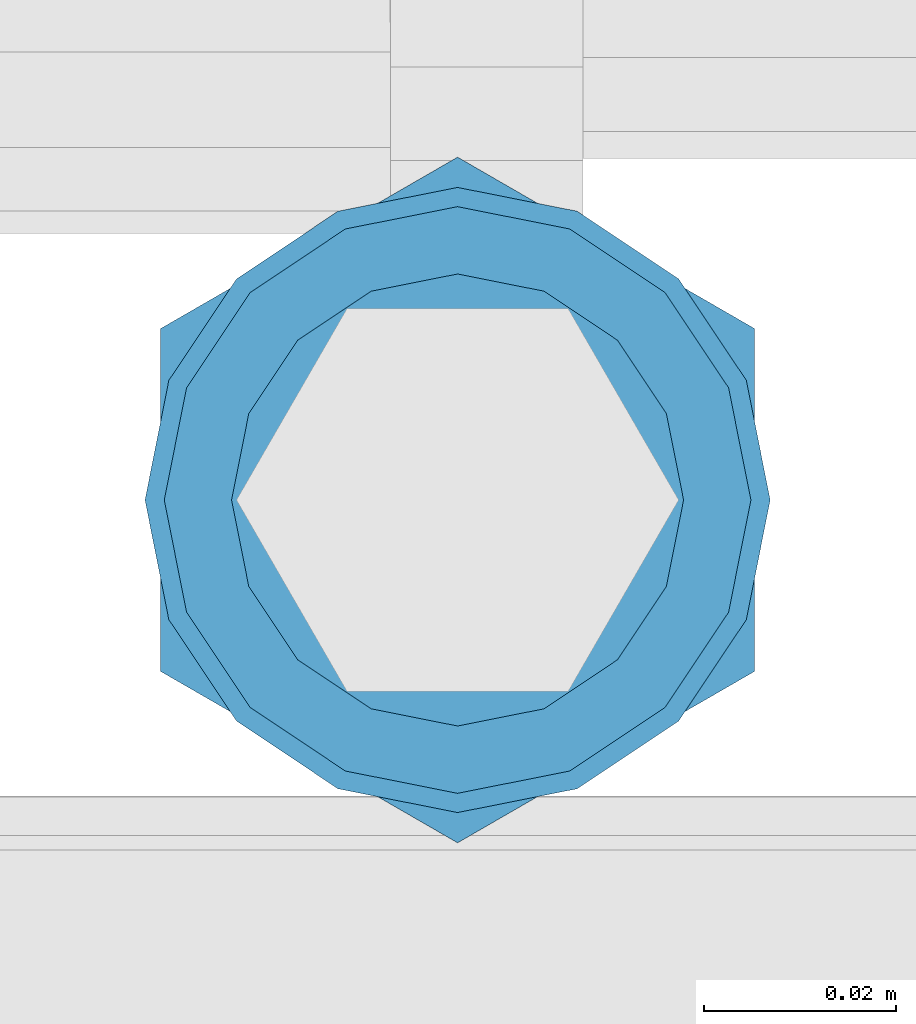
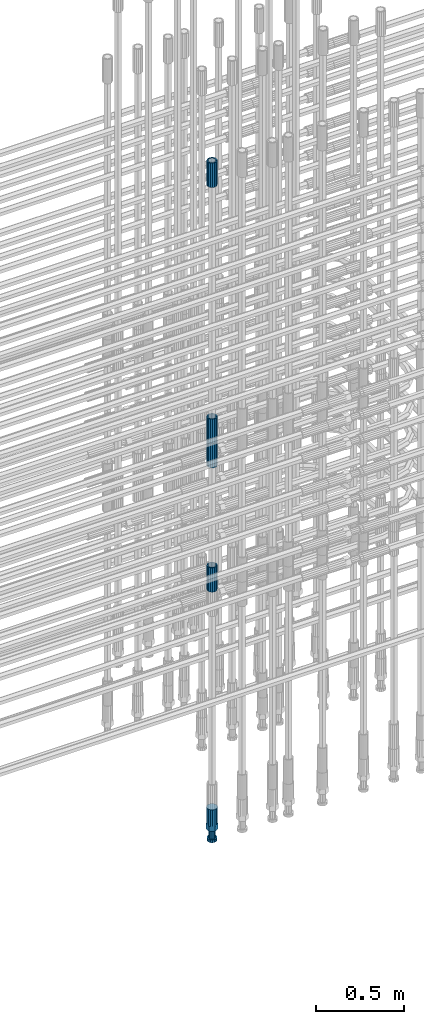
# One storey, part 20 of 119: 5 beams.
"""IFC2X3 building model written with IfcOpenShell, lengths in millimetres."""

from ifc_helpers import new_model, si_unit, frame, origin_with_axes, place, context, subcontext, project, spatial, faceted_brep, material, type_object, element, save


model = new_model("IFC2X3")

# Units and contexts
model_context = context("Model", 3, precision=1e-05, world=origin_with_axes())
body_context = subcontext(model_context, "Body", "Model", "MODEL_VIEW")
ifc_project = project(units=[si_unit("LENGTHUNIT", "METRE", prefix="MILLI"), si_unit("AREAUNIT", "SQUARE_METRE"), si_unit("VOLUMEUNIT", "CUBIC_METRE"), si_unit("MASSUNIT", "GRAM", prefix="KILO"), si_unit("TIMEUNIT", "SECOND"), si_unit("PLANEANGLEUNIT", "RADIAN"), si_unit("SOLIDANGLEUNIT", "STERADIAN"), si_unit("THERMODYNAMICTEMPERATUREUNIT", "DEGREE_CELSIUS"), si_unit("LUMINOUSINTENSITYUNIT", "LUMEN")], contexts=[model_context])

# Site, building, storey
site_placement = place(None, origin_with_axes())
site = spatial("IfcSite", under=ifc_project, at=site_placement, CompositionType="ELEMENT")
building_placement = place(site_placement, origin_with_axes())
building = spatial("IfcBuilding", under=site, at=building_placement, Name="Undefined", CompositionType="ELEMENT")
storey_placement = place(building_placement, origin_with_axes())
storey = spatial("IfcBuildingStorey", under=building, at=storey_placement, Name="Undefined", CompositionType="ELEMENT", Elevation=0.0)

# Beams
ifc_material = material(Name="STEEL/S275")
beam_type_1 = type_object("IfcBeamType", PredefinedType="NOTDEFINED")
beam_1_placement = place(storey_placement, frame((2035126.00651562, 6205153.77086634, 20704.6057291644), z_axis=(1.0, 0.0, 0.0), x_axis=(0.0, 0.0, 1.0)))
element("IfcBeam", 1, at=beam_1_placement, inside=storey, type_object=beam_type_1, material=ifc_material, Name="AG40N", context=body_context, shape_type="Brep", body=[
    faceted_brep([(1.62981450557709e-09, -23.4999999990687, 0.0), (7.45058059692383e-09, -21.7111690142192, 8.99306066057534), (170.000002125278, -21.711168999318, 8.99306066022245), (170.000002127141, -23.4999999844003, -3.66071617463604e-10), (4.65661287307739e-09, -16.6170093587134, 16.6170093578889), (170.000002122484, -16.6170093440451, 16.6170093575288), (1.86264514923096e-09, -8.99306066217832, 21.7111690140277), (170.000002118759, -8.99306064750999, 21.7111690136603), (2.3283064365387e-10, 9.31322574615479e-10, 23.5), (170.000002114102, 1.28056854009628e-08, 23.4999999996485), (-6.51925802230835e-09, 8.99306065868586, 21.7111690140241), (170.00000211224, 8.99306067335419, 21.7111690136639), (-7.45058059692383e-09, 16.6170093561523, 16.6170093578853), (170.000002109446, 16.6170093708206, 16.6170093575324), (-9.31322574615479e-09, 21.711169013055, 8.99306066057534), (170.000002108514, 21.7111690277234, 8.99306066022245), (-1.16415321826935e-09, 23.5000000009313, 0.0), (170.000002108514, 23.5000000144355, -3.66071617463604e-10), (-8.38190317153931e-09, 21.7111690151505, -8.99306066059444), (170.000002110377, 21.7111690300517, -8.9930606609546), (-5.58793544769287e-09, 16.6170093598776, -16.6170093579008), (170.000002113171, 16.6170093745459, -16.6170093582609), (-9.31322574615479e-10, 8.99306066334248, -21.7111690140396), (170.000002115965, 8.99306067801081, -21.7111690143961), (2.3283064365387e-10, 9.31322574615479e-10, -23.5), (170.00000211969, 1.7927959561348e-08, -23.5000000003843), (5.58793544769287e-09, -8.99306065752171, -21.7111690140396), (170.000002123415, -8.99306064285338, -21.7111690143961), (8.38190317153931e-09, -16.6170093549881, -16.6170093579008), (170.000002125278, -16.6170093403198, -16.6170093582646), (9.31322574615479e-09, -21.7111690121237, -8.99306066059444), (170.000002127141, -21.7111689972226, -8.9930606609546), (1.11758708953857e-08, -30.4999999990687, -9.54969436861575e-12), (1.30385160446167e-08, -28.1783257392235, -11.6718446871514), (170.000002129003, -28.1783257243223, -11.6718446875116), (170.000002129935, -30.4999999841675, -3.66071617463604e-10), (1.02445483207703e-08, -21.5667568228673, -21.5667568262129), (170.000002128072, -21.566756808199, -21.5667568265694), (7.45058059692383e-09, -11.6718446831219, -28.1783257416196), (170.000002125278, -11.6718446684536, -28.1783257419834), (3.72529029846191e-09, 3.95812094211578e-09, -30.5000000000277), (170.00000211969, 1.83936208486557e-08, -30.5000000003879), (-9.31322574615479e-10, 11.6718446905725, -28.1783257416232), (170.000002115965, 11.6718447052408, -28.1783257419797), (-6.51925802230835e-09, 21.5667568286881, -21.5667568262093), (170.000002110377, 21.5667568433564, -21.5667568265694), (-9.31322574615479e-09, 28.178325742716, -11.6718446871478), (170.000002108514, 28.1783257573843, -11.6718446875079), (-1.21071934700012e-08, 30.5, -5.91171556152403e-12), (170.000002106652, 30.5000000144355, -3.62433638656512e-10), (-1.21071934700012e-08, 28.1783257401548, 11.6718446871359), (170.00000210572, 28.1783257548232, 11.6718446867794), (-1.02445483207703e-08, 21.5667568240315, 21.5667568261974), (170.000002107583, 21.566756838467, 21.5667568258409), (-7.45058059692383e-09, 11.671844684286, 28.1783257416041), (170.000002110377, 11.6718446989544, 28.178325741244), (-2.79396772384644e-09, -2.56113708019257e-09, 30.5000000000159), (170.000002114102, 1.18743628263474e-08, 30.4999999996558), (1.86264514923096e-09, -11.6718446896411, 28.1783257416114), (170.000002118759, -11.67184467474, 28.178325741244), (7.45058059692383e-09, -21.5667568275239, 21.5667568261974), (170.000002123415, -21.5667568126228, 21.5667568258373), (1.02445483207703e-08, -28.1783257415518, 11.6718446871359), (170.000002127141, -28.1783257271163, 11.6718446867794)], [[[0, 1, 2, 3]], [[1, 4, 5, 2]], [[4, 6, 7, 5]], [[6, 8, 9, 7]], [[8, 10, 11, 9]], [[10, 12, 13, 11]], [[12, 14, 15, 13]], [[14, 16, 17, 15]], [[16, 18, 19, 17]], [[18, 20, 21, 19]], [[20, 22, 23, 21]], [[22, 24, 25, 23]], [[24, 26, 27, 25]], [[26, 28, 29, 27]], [[28, 30, 31, 29]], [[30, 0, 3, 31]], [[32, 33, 34, 35]], [[33, 36, 37, 34]], [[36, 38, 39, 37]], [[38, 40, 41, 39]], [[40, 42, 43, 41]], [[42, 44, 45, 43]], [[44, 46, 47, 45]], [[46, 48, 49, 47]], [[48, 50, 51, 49]], [[50, 52, 53, 51]], [[52, 54, 55, 53]], [[54, 56, 57, 55]], [[56, 58, 59, 57]], [[58, 60, 61, 59]], [[60, 62, 63, 61]], [[62, 32, 35, 63]], [[37, 39, 41, 43, 45, 47, 49, 51, 53, 55, 57, 59, 61, 63, 35, 34], [5, 7, 9, 11, 13, 15, 17, 19, 21, 23, 25, 27, 29, 31, 3, 2]], [[62, 60, 58, 56, 54, 52, 50, 48, 46, 44, 42, 40, 38, 36, 33, 32], [30, 28, 26, 24, 22, 20, 18, 16, 14, 12, 10, 8, 6, 4, 1, 0]]]),
])
beam_2_placement = place(storey_placement, frame((2035126.00651562, 6205153.77086634, 20007.7168583153), z_axis=(-0.99999999999998, 1.98000110685822e-07, 0.0), x_axis=(0.0, 0.0, -1.0)))
element("IfcBeam", 2, at=beam_2_placement, inside=storey, type_object=beam_type_1, material=ifc_material, Name="AG40N", context=body_context, shape_type="Brep", body=[
    faceted_brep([(1.62981450557709e-09, -23.4999999990687, 0.0), (7.45058059692383e-09, -21.7111690142192, 8.99306066057534), (170.000002125278, -21.711168999318, 8.99306066022245), (170.000002127141, -23.4999999844003, -3.66071617463604e-10), (4.65661287307739e-09, -16.6170093587134, 16.6170093578889), (170.000002122484, -16.6170093440451, 16.6170093575288), (1.86264514923096e-09, -8.99306066217832, 21.7111690140277), (170.000002118759, -8.99306064750999, 21.7111690136603), (2.3283064365387e-10, 9.31322574615479e-10, 23.5), (170.000002114102, 1.28056854009628e-08, 23.4999999996485), (-6.51925802230835e-09, 8.99306065868586, 21.7111690140241), (170.00000211224, 8.99306067335419, 21.7111690136639), (-7.45058059692383e-09, 16.6170093561523, 16.6170093578853), (170.000002109446, 16.6170093708206, 16.6170093575324), (-9.31322574615479e-09, 21.711169013055, 8.99306066057534), (170.000002108514, 21.7111690277234, 8.99306066022245), (-1.16415321826935e-09, 23.5000000009313, 0.0), (170.000002108514, 23.5000000144355, -3.66071617463604e-10), (-8.38190317153931e-09, 21.7111690151505, -8.99306066059444), (170.000002110377, 21.7111690300517, -8.9930606609546), (-5.58793544769287e-09, 16.6170093598776, -16.6170093579008), (170.000002113171, 16.6170093745459, -16.6170093582609), (-9.31322574615479e-10, 8.99306066334248, -21.7111690140396), (170.000002115965, 8.99306067801081, -21.7111690143961), (2.3283064365387e-10, 9.31322574615479e-10, -23.5), (170.00000211969, 1.7927959561348e-08, -23.5000000003843), (5.58793544769287e-09, -8.99306065752171, -21.7111690140396), (170.000002123415, -8.99306064285338, -21.7111690143961), (8.38190317153931e-09, -16.6170093549881, -16.6170093579008), (170.000002125278, -16.6170093403198, -16.6170093582646), (9.31322574615479e-09, -21.7111690121237, -8.99306066059444), (170.000002127141, -21.7111689972226, -8.9930606609546), (1.11758708953857e-08, -30.4999999990687, -9.54969436861575e-12), (1.30385160446167e-08, -28.1783257392235, -11.6718446871514), (170.000002129003, -28.1783257243223, -11.6718446875116), (170.000002129935, -30.4999999841675, -3.66071617463604e-10), (1.02445483207703e-08, -21.5667568228673, -21.5667568262129), (170.000002128072, -21.566756808199, -21.5667568265694), (7.45058059692383e-09, -11.6718446831219, -28.1783257416196), (170.000002125278, -11.6718446684536, -28.1783257419834), (3.72529029846191e-09, 3.95812094211578e-09, -30.5000000000277), (170.00000211969, 1.83936208486557e-08, -30.5000000003879), (-9.31322574615479e-10, 11.6718446905725, -28.1783257416232), (170.000002115965, 11.6718447052408, -28.1783257419797), (-6.51925802230835e-09, 21.5667568286881, -21.5667568262093), (170.000002110377, 21.5667568433564, -21.5667568265694), (-9.31322574615479e-09, 28.178325742716, -11.6718446871478), (170.000002108514, 28.1783257573843, -11.6718446875079), (-1.21071934700012e-08, 30.5, -5.91171556152403e-12), (170.000002106652, 30.5000000144355, -3.62433638656512e-10), (-1.21071934700012e-08, 28.1783257401548, 11.6718446871359), (170.00000210572, 28.1783257548232, 11.6718446867794), (-1.02445483207703e-08, 21.5667568240315, 21.5667568261974), (170.000002107583, 21.566756838467, 21.5667568258409), (-7.45058059692383e-09, 11.671844684286, 28.1783257416041), (170.000002110377, 11.6718446989544, 28.178325741244), (-2.79396772384644e-09, -2.56113708019257e-09, 30.5000000000159), (170.000002114102, 1.18743628263474e-08, 30.4999999996558), (1.86264514923096e-09, -11.6718446896411, 28.1783257416114), (170.000002118759, -11.67184467474, 28.178325741244), (7.45058059692383e-09, -21.5667568275239, 21.5667568261974), (170.000002123415, -21.5667568126228, 21.5667568258373), (1.02445483207703e-08, -28.1783257415518, 11.6718446871359), (170.000002127141, -28.1783257271163, 11.6718446867794)], [[[0, 1, 2, 3]], [[1, 4, 5, 2]], [[4, 6, 7, 5]], [[6, 8, 9, 7]], [[8, 10, 11, 9]], [[10, 12, 13, 11]], [[12, 14, 15, 13]], [[14, 16, 17, 15]], [[16, 18, 19, 17]], [[18, 20, 21, 19]], [[20, 22, 23, 21]], [[22, 24, 25, 23]], [[24, 26, 27, 25]], [[26, 28, 29, 27]], [[28, 30, 31, 29]], [[30, 0, 3, 31]], [[32, 33, 34, 35]], [[33, 36, 37, 34]], [[36, 38, 39, 37]], [[38, 40, 41, 39]], [[40, 42, 43, 41]], [[42, 44, 45, 43]], [[44, 46, 47, 45]], [[46, 48, 49, 47]], [[48, 50, 51, 49]], [[50, 52, 53, 51]], [[52, 54, 55, 53]], [[54, 56, 57, 55]], [[56, 58, 59, 57]], [[58, 60, 61, 59]], [[60, 62, 63, 61]], [[62, 32, 35, 63]], [[37, 39, 41, 43, 45, 47, 49, 51, 53, 55, 57, 59, 61, 63, 35, 34], [5, 7, 9, 11, 13, 15, 17, 19, 21, 23, 25, 27, 29, 31, 3, 2]], [[62, 60, 58, 56, 54, 52, 50, 48, 46, 44, 42, 40, 38, 36, 33, 32], [30, 28, 26, 24, 22, 20, 18, 16, 14, 12, 10, 8, 6, 4, 1, 0]]]),
])
beam_3_placement = place(storey_placement, frame((2035126.00651562, 6205153.77086634, 22659.9857291644), z_axis=(1.0, 0.0, 0.0), x_axis=(0.0, 0.0, 1.0)))
element("IfcBeam", 3, at=beam_3_placement, inside=storey, type_object=beam_type_1, material=ifc_material, Name="AG40N", context=body_context, shape_type="Brep", body=[
    faceted_brep([(1.62981450557709e-09, -23.4999999990687, 0.0), (7.45058059692383e-09, -21.7111690142192, 8.99306066057534), (170.000002125278, -21.711168999318, 8.99306066022245), (170.000002127141, -23.4999999844003, -3.66071617463604e-10), (4.65661287307739e-09, -16.6170093587134, 16.6170093578889), (170.000002122484, -16.6170093440451, 16.6170093575288), (1.86264514923096e-09, -8.99306066217832, 21.7111690140277), (170.000002118759, -8.99306064750999, 21.7111690136603), (2.3283064365387e-10, 9.31322574615479e-10, 23.5), (170.000002114102, 1.28056854009628e-08, 23.4999999996485), (-6.51925802230835e-09, 8.99306065868586, 21.7111690140241), (170.00000211224, 8.99306067335419, 21.7111690136639), (-7.45058059692383e-09, 16.6170093561523, 16.6170093578853), (170.000002109446, 16.6170093708206, 16.6170093575324), (-9.31322574615479e-09, 21.711169013055, 8.99306066057534), (170.000002108514, 21.7111690277234, 8.99306066022245), (-1.16415321826935e-09, 23.5000000009313, 0.0), (170.000002108514, 23.5000000144355, -3.66071617463604e-10), (-8.38190317153931e-09, 21.7111690151505, -8.99306066059444), (170.000002110377, 21.7111690300517, -8.9930606609546), (-5.58793544769287e-09, 16.6170093598776, -16.6170093579008), (170.000002113171, 16.6170093745459, -16.6170093582609), (-9.31322574615479e-10, 8.99306066334248, -21.7111690140396), (170.000002115965, 8.99306067801081, -21.7111690143961), (2.3283064365387e-10, 9.31322574615479e-10, -23.5), (170.00000211969, 1.7927959561348e-08, -23.5000000003843), (5.58793544769287e-09, -8.99306065752171, -21.7111690140396), (170.000002123415, -8.99306064285338, -21.7111690143961), (8.38190317153931e-09, -16.6170093549881, -16.6170093579008), (170.000002125278, -16.6170093403198, -16.6170093582646), (9.31322574615479e-09, -21.7111690121237, -8.99306066059444), (170.000002127141, -21.7111689972226, -8.9930606609546), (1.11758708953857e-08, -30.4999999990687, -9.54969436861575e-12), (1.30385160446167e-08, -28.1783257392235, -11.6718446871514), (170.000002129003, -28.1783257243223, -11.6718446875116), (170.000002129935, -30.4999999841675, -3.66071617463604e-10), (1.02445483207703e-08, -21.5667568228673, -21.5667568262129), (170.000002128072, -21.566756808199, -21.5667568265694), (7.45058059692383e-09, -11.6718446831219, -28.1783257416196), (170.000002125278, -11.6718446684536, -28.1783257419834), (3.72529029846191e-09, 3.95812094211578e-09, -30.5000000000277), (170.00000211969, 1.83936208486557e-08, -30.5000000003879), (-9.31322574615479e-10, 11.6718446905725, -28.1783257416232), (170.000002115965, 11.6718447052408, -28.1783257419797), (-6.51925802230835e-09, 21.5667568286881, -21.5667568262093), (170.000002110377, 21.5667568433564, -21.5667568265694), (-9.31322574615479e-09, 28.178325742716, -11.6718446871478), (170.000002108514, 28.1783257573843, -11.6718446875079), (-1.21071934700012e-08, 30.5, -5.91171556152403e-12), (170.000002106652, 30.5000000144355, -3.62433638656512e-10), (-1.21071934700012e-08, 28.1783257401548, 11.6718446871359), (170.00000210572, 28.1783257548232, 11.6718446867794), (-1.02445483207703e-08, 21.5667568240315, 21.5667568261974), (170.000002107583, 21.566756838467, 21.5667568258409), (-7.45058059692383e-09, 11.671844684286, 28.1783257416041), (170.000002110377, 11.6718446989544, 28.178325741244), (-2.79396772384644e-09, -2.56113708019257e-09, 30.5000000000159), (170.000002114102, 1.18743628263474e-08, 30.4999999996558), (1.86264514923096e-09, -11.6718446896411, 28.1783257416114), (170.000002118759, -11.67184467474, 28.178325741244), (7.45058059692383e-09, -21.5667568275239, 21.5667568261974), (170.000002123415, -21.5667568126228, 21.5667568258373), (1.02445483207703e-08, -28.1783257415518, 11.6718446871359), (170.000002127141, -28.1783257271163, 11.6718446867794)], [[[0, 1, 2, 3]], [[1, 4, 5, 2]], [[4, 6, 7, 5]], [[6, 8, 9, 7]], [[8, 10, 11, 9]], [[10, 12, 13, 11]], [[12, 14, 15, 13]], [[14, 16, 17, 15]], [[16, 18, 19, 17]], [[18, 20, 21, 19]], [[20, 22, 23, 21]], [[22, 24, 25, 23]], [[24, 26, 27, 25]], [[26, 28, 29, 27]], [[28, 30, 31, 29]], [[30, 0, 3, 31]], [[32, 33, 34, 35]], [[33, 36, 37, 34]], [[36, 38, 39, 37]], [[38, 40, 41, 39]], [[40, 42, 43, 41]], [[42, 44, 45, 43]], [[44, 46, 47, 45]], [[46, 48, 49, 47]], [[48, 50, 51, 49]], [[50, 52, 53, 51]], [[52, 54, 55, 53]], [[54, 56, 57, 55]], [[56, 58, 59, 57]], [[58, 60, 61, 59]], [[60, 62, 63, 61]], [[62, 32, 35, 63]], [[37, 39, 41, 43, 45, 47, 49, 51, 53, 55, 57, 59, 61, 63, 35, 34], [5, 7, 9, 11, 13, 15, 17, 19, 21, 23, 25, 27, 29, 31, 3, 2]], [[62, 60, 58, 56, 54, 52, 50, 48, 46, 44, 42, 40, 38, 36, 33, 32], [30, 28, 26, 24, 22, 20, 18, 16, 14, 12, 10, 8, 6, 4, 1, 0]]]),
])
beam_4_placement = place(storey_placement, frame((2035126.00651562, 6205153.77086634, 21044.6068583146), z_axis=(-0.99999999999998, 1.98000110685822e-07, 0.0), x_axis=(0.0, 0.0, -1.0)))
element("IfcBeam", 4, at=beam_4_placement, inside=storey, type_object=beam_type_1, material=ifc_material, Name="AG40N", context=body_context, shape_type="Brep", body=[
    faceted_brep([(1.62981450557709e-09, -23.4999999990687, 0.0), (7.45058059692383e-09, -21.7111690142192, 8.99306066057534), (170.000002125278, -21.711168999318, 8.99306066022245), (170.000002127141, -23.4999999844003, -3.66071617463604e-10), (4.65661287307739e-09, -16.6170093587134, 16.6170093578889), (170.000002122484, -16.6170093440451, 16.6170093575288), (1.86264514923096e-09, -8.99306066217832, 21.7111690140277), (170.000002118759, -8.99306064750999, 21.7111690136603), (2.3283064365387e-10, 9.31322574615479e-10, 23.5), (170.000002114102, 1.28056854009628e-08, 23.4999999996485), (-6.51925802230835e-09, 8.99306065868586, 21.7111690140241), (170.00000211224, 8.99306067335419, 21.7111690136639), (-7.45058059692383e-09, 16.6170093561523, 16.6170093578853), (170.000002109446, 16.6170093708206, 16.6170093575324), (-9.31322574615479e-09, 21.711169013055, 8.99306066057534), (170.000002108514, 21.7111690277234, 8.99306066022245), (-1.16415321826935e-09, 23.5000000009313, 0.0), (170.000002108514, 23.5000000144355, -3.66071617463604e-10), (-8.38190317153931e-09, 21.7111690151505, -8.99306066059444), (170.000002110377, 21.7111690300517, -8.9930606609546), (-5.58793544769287e-09, 16.6170093598776, -16.6170093579008), (170.000002113171, 16.6170093745459, -16.6170093582609), (-9.31322574615479e-10, 8.99306066334248, -21.7111690140396), (170.000002115965, 8.99306067801081, -21.7111690143961), (2.3283064365387e-10, 9.31322574615479e-10, -23.5), (170.00000211969, 1.7927959561348e-08, -23.5000000003843), (5.58793544769287e-09, -8.99306065752171, -21.7111690140396), (170.000002123415, -8.99306064285338, -21.7111690143961), (8.38190317153931e-09, -16.6170093549881, -16.6170093579008), (170.000002125278, -16.6170093403198, -16.6170093582646), (9.31322574615479e-09, -21.7111690121237, -8.99306066059444), (170.000002127141, -21.7111689972226, -8.9930606609546), (1.11758708953857e-08, -30.4999999990687, -9.54969436861575e-12), (1.30385160446167e-08, -28.1783257392235, -11.6718446871514), (170.000002129003, -28.1783257243223, -11.6718446875116), (170.000002129935, -30.4999999841675, -3.66071617463604e-10), (1.02445483207703e-08, -21.5667568228673, -21.5667568262129), (170.000002128072, -21.566756808199, -21.5667568265694), (7.45058059692383e-09, -11.6718446831219, -28.1783257416196), (170.000002125278, -11.6718446684536, -28.1783257419834), (3.72529029846191e-09, 3.95812094211578e-09, -30.5000000000277), (170.00000211969, 1.83936208486557e-08, -30.5000000003879), (-9.31322574615479e-10, 11.6718446905725, -28.1783257416232), (170.000002115965, 11.6718447052408, -28.1783257419797), (-6.51925802230835e-09, 21.5667568286881, -21.5667568262093), (170.000002110377, 21.5667568433564, -21.5667568265694), (-9.31322574615479e-09, 28.178325742716, -11.6718446871478), (170.000002108514, 28.1783257573843, -11.6718446875079), (-1.21071934700012e-08, 30.5, -5.91171556152403e-12), (170.000002106652, 30.5000000144355, -3.62433638656512e-10), (-1.21071934700012e-08, 28.1783257401548, 11.6718446871359), (170.00000210572, 28.1783257548232, 11.6718446867794), (-1.02445483207703e-08, 21.5667568240315, 21.5667568261974), (170.000002107583, 21.566756838467, 21.5667568258409), (-7.45058059692383e-09, 11.671844684286, 28.1783257416041), (170.000002110377, 11.6718446989544, 28.178325741244), (-2.79396772384644e-09, -2.56113708019257e-09, 30.5000000000159), (170.000002114102, 1.18743628263474e-08, 30.4999999996558), (1.86264514923096e-09, -11.6718446896411, 28.1783257416114), (170.000002118759, -11.67184467474, 28.178325741244), (7.45058059692383e-09, -21.5667568275239, 21.5667568261974), (170.000002123415, -21.5667568126228, 21.5667568258373), (1.02445483207703e-08, -28.1783257415518, 11.6718446871359), (170.000002127141, -28.1783257271163, 11.6718446867794)], [[[0, 1, 2, 3]], [[1, 4, 5, 2]], [[4, 6, 7, 5]], [[6, 8, 9, 7]], [[8, 10, 11, 9]], [[10, 12, 13, 11]], [[12, 14, 15, 13]], [[14, 16, 17, 15]], [[16, 18, 19, 17]], [[18, 20, 21, 19]], [[20, 22, 23, 21]], [[22, 24, 25, 23]], [[24, 26, 27, 25]], [[26, 28, 29, 27]], [[28, 30, 31, 29]], [[30, 0, 3, 31]], [[32, 33, 34, 35]], [[33, 36, 37, 34]], [[36, 38, 39, 37]], [[38, 40, 41, 39]], [[40, 42, 43, 41]], [[42, 44, 45, 43]], [[44, 46, 47, 45]], [[46, 48, 49, 47]], [[48, 50, 51, 49]], [[50, 52, 53, 51]], [[52, 54, 55, 53]], [[54, 56, 57, 55]], [[56, 58, 59, 57]], [[58, 60, 61, 59]], [[60, 62, 63, 61]], [[62, 32, 35, 63]], [[37, 39, 41, 43, 45, 47, 49, 51, 53, 55, 57, 59, 61, 63, 35, 34], [5, 7, 9, 11, 13, 15, 17, 19, 21, 23, 25, 27, 29, 31, 3, 2]], [[62, 60, 58, 56, 54, 52, 50, 48, 46, 44, 42, 40, 38, 36, 33, 32], [30, 28, 26, 24, 22, 20, 18, 16, 14, 12, 10, 8, 6, 4, 1, 0]]]),
])
beam_type_2 = type_object("IfcBeamType", Name="ROD65", PredefinedType="NOTDEFINED")
beam_5_placement = place(storey_placement, frame((2035126.00651562, 6205153.77086634, 18320.9668583153), z_axis=(-0.99999999999998, 1.98000110685822e-07, 0.0), x_axis=(0.0, 0.0, -1.0)))
element("IfcBeam", 5, at=beam_5_placement, inside=storey, type_object=beam_type_2, material=ifc_material, Name="AGB40", ObjectType="ROD65", context=body_context, shape_type="Brep", body=[
    faceted_brep([(116.999999999069, 17.8249999252148, 30.8738056446964), (116.999999998137, 22.0056957420893, 23.632628078838), (116.999999999069, 12.4372115600854, 30.0260848066173), (116.999999999069, 8.17543111252598, 30.8738056446964), (117.000000000931, -17.8250000746921, 30.8738056446964), (150.200000001118, -17.8250000723638, 30.8738056446964), (150.199999999255, 17.8249999275431, 30.8738056446964), (117.000000000931, -8.17543109622784, 30.8738056446964), (117.000000001863, -22.0056959956419, 23.6326278985034), (117.000000000931, -12.4372115437873, 30.0260848066173), (117.000000001863, -35.6500000746455, -2.18278728425503e-10), (150.200000002049, -35.6500000723172, -2.18278728425503e-10), (117.000000001863, -30.8443149488885, 8.32369080289209), (117.000000001863, -30.8443149488885, -8.32369080355784), (117.000000002794, -32.4999999918509, 0.0), (117.000000000931, -17.8250000746921, -30.873805645133), (150.200000001118, -17.8250000723638, -30.873805645133), (117.000000001863, -22.0056959961075, -23.6326278982269), (117.000000000931, -8.17543109389953, -30.873805645133), (117.000000000931, -12.4372115437873, -30.0260848066173), (116.999999999069, 17.8249999252148, -30.873805645133), (150.199999999255, 17.8249999275431, -30.873805645133), (116.999999999069, 8.17543111019768, -30.873805645133), (116.999999999069, 12.4372115600854, -30.0260848066173), (116.999999998137, 22.005695742555, -23.6326280785652), (116.999999998137, 35.6499999251682, -2.18278728425503e-10), (150.199999998324, 35.6499999277294, -2.18278728425503e-10), (116.999999998137, 30.8443150522653, -8.32369036550881), (116.999999997206, 32.5000000081491, 0.0), (116.999999998137, 30.8443150522653, 8.32369036483942), (1.86264514923096e-09, -22.9809703885112, 22.9809703885621), (1.86264514923096e-09, -30.0260848065373, 12.4372115518672), (117.000000001863, -30.0260847983882, 12.4372115518672), (117.000000001863, -22.9809703803621, 22.9809703885621), (-1.86264514923096e-09, 22.9809703885112, -22.9809703885621), (-1.86264514923096e-09, 30.0260848065373, -12.4372115518672), (116.999999998137, 30.0260848146863, -12.4372115518672), (116.999999998137, 22.9809703966603, -22.9809703885621), (1.86264514923096e-09, -30.0260848065373, -12.4372115518672), (1.86264514923096e-09, -22.9809703885112, -22.9809703885621), (117.000000001863, -22.9809703803621, -22.9809703885621), (117.000000001863, -30.0260847983882, -12.4372115518672), (9.31322574615479e-10, -12.4372115519363, 30.0260848066173), (0.0, 0.0, 32.5), (-9.31322574615479e-10, 12.4372115519363, 30.0260848066173), (-1.86264514923096e-09, 22.9809703885112, 22.9809703885621), (-1.86264514923096e-09, 30.0260848065373, 12.4372115518672), (-2.79396772384644e-09, 32.5, 0.0), (-9.31322574615479e-10, 12.4372115519363, -30.0260848066173), (0.0, 0.0, -32.5), (9.31322574615479e-10, -12.4372115519363, -30.0260848066173), (2.79396772384644e-09, -32.5, 0.0), (116.999999998137, 22.9809703966603, 22.9809703885621), (116.999999998137, 30.0260848146863, 12.4372115518672), (117.0, 8.14907252788544e-09, -32.5), (117.0, 8.14907252788544e-09, 32.5), (150.200000000186, -10.5000000959262, 18.1865334791873), (150.199999999255, -9.59262251853943e-08, 20.9999999997126), (150.199999998324, 10.4999999040738, 18.1865334791873), (150.199999997392, 18.1865333835594, 10.4999999997126), (150.199999997392, 20.9999999040738, -2.87400325760245e-10), (150.199999997392, 18.1865333835594, -10.5000000002874), (150.199999998324, 10.4999999040738, -18.1865334797621), (150.199999999255, -9.59262251853943e-08, -21.0000000002874), (150.200000000186, -10.5000000959262, -18.1865334797621), (150.200000000186, -18.1865335754119, -10.5000000002874), (150.200000001118, -21.0000000959262, -2.87400325760245e-10), (150.200000000186, -18.1865335754119, 10.4999999997126), (210.979999999516, 10.4999999082647, 18.1865334791873), (210.979999999516, -9.17352735996246e-08, 20.9999999997126), (210.979999997653, 18.1865333877504, 10.4999999997126), (210.979999997653, 20.9999999082647, -2.87400325760245e-10), (210.979999997653, 18.1865333877504, -10.5000000002874), (210.979999999516, 10.4999999082647, -18.1865334797621), (210.979999999516, -9.17352735996246e-08, -21.0000000002874), (210.979999999516, -10.5000000917353, -18.1865334797621), (210.980000000447, -18.1865335712209, -10.5000000002874), (210.980000001378, -21.0000000917353, -2.87400325760245e-10), (210.980000000447, -18.1865335712209, 10.4999999997126), (210.979999999516, -10.5000000917353, 18.1865334791873), (211.001368402503, -27.7269939335529, -11.4911163272045), (211.003082515672, -21.2238095656503, -21.2238154190527), (231.002518340945, -21.2131946226582, -21.2132004554769), (231.000804228708, -27.7163789905608, -11.4805013636287), (211.001368415542, -11.4911086384673, -27.7269970399575), (231.000804241747, -11.4804936954752, -27.7163820763781), (210.996487061493, -0.0106066407170147, -30.0106107396168), (230.995922887698, 8.30227509140968e-06, -29.999995776041), (210.98918159306, 11.4698940692469, -27.7269970332745), (230.988617419265, 11.4805090120062, -27.7163820696951), (210.980564201251, 21.2025913291145, -21.2238154067054), (230.980000027455, 21.2132062721066, -21.2132004431296), (210.971946807578, 27.7057702087332, -11.4911163110701), (230.971382633783, 27.7163851517253, -11.4805013474943), (210.964641331695, 29.9893806746695, -0.0106149565435771), (230.9640771579, 29.9999956176616, 7.03221303410828e-09), (210.959759964608, 27.7057637346443, 11.4698863966551), (230.959195790812, 27.7163786776364, 11.4805013602345), (210.958045851439, 21.2025793667417, 21.2025854885032), (230.957481677644, 21.2131943097338, 21.2132004520827), (210.959759951569, 11.4698784395587, 27.705767109408), (230.959195776843, 11.4804933823179, 27.7163820729838), (210.964641305618, -0.0106235581915826, 29.9893808090674), (230.964077131823, -8.61519947648048e-06, 29.9999957726432), (210.971946774051, -11.4911242681555, 27.7057671027251), (230.971382599324, -11.4805093251634, 27.7163820663009), (210.98056416586, -21.2238215280231, 21.2025854761559), (230.979999991134, -21.2132065852638, 21.2132004397354), (210.989181559533, -27.7270004076418, 11.4698863805206), (230.988617384806, -27.7163854646496, 11.4805013441), (210.996487035416, -30.0106108735781, -0.0106149740058754), (230.995922861621, -29.999995930586, -1.04300852399319e-08)], [[[0, 1, 2, 3]], [[4, 5, 6, 0, 3, 7]], [[8, 4, 7, 9]], [[10, 11, 5, 4, 8, 12]], [[13, 10, 12, 14]], [[15, 16, 11, 10, 13, 17]], [[18, 15, 17, 19]], [[20, 21, 16, 15, 18, 22]], [[20, 22, 23, 24]], [[25, 26, 21, 20, 24, 27]], [[25, 27, 28, 29]], [[30, 31, 32, 33]], [[34, 35, 36, 37]], [[38, 39, 40, 41]], [[31, 30, 42, 43, 44, 45, 46, 47, 35, 34, 48, 49, 50, 39, 38, 51]], [[46, 45, 52, 53]], [[28, 47, 46, 53, 29]], [[27, 36, 35, 47, 28]], [[24, 37, 36, 27]], [[23, 48, 34, 37, 24]], [[22, 54, 49, 48, 23]], [[18, 54, 22]], [[19, 50, 49, 54, 18]], [[17, 40, 39, 50, 19]], [[13, 41, 40, 17]], [[14, 51, 38, 41, 13]], [[12, 32, 31, 51, 14]], [[8, 33, 32, 12]], [[9, 42, 30, 33, 8]], [[7, 55, 43, 42, 9]], [[3, 55, 7]], [[2, 44, 43, 55, 3]], [[1, 52, 45, 44, 2]], [[29, 53, 52, 1]], [[0, 6, 26, 25, 29, 1]], [[5, 11, 16, 21, 26, 6], [56, 57, 58, 59, 60, 61, 62, 63, 64, 65, 66, 67]], [[68, 58, 57, 69]], [[70, 59, 58, 68]], [[71, 60, 59, 70]], [[72, 61, 60, 71]], [[73, 62, 61, 72]], [[74, 63, 62, 73]], [[75, 64, 63, 74]], [[76, 65, 64, 75]], [[77, 66, 65, 76]], [[78, 67, 66, 77]], [[79, 56, 67, 78]], [[69, 57, 56, 79]], [[80, 81, 82, 83]], [[81, 84, 85, 82]], [[84, 86, 87, 85]], [[86, 88, 89, 87]], [[88, 90, 91, 89]], [[90, 92, 93, 91]], [[92, 94, 95, 93]], [[94, 96, 97, 95]], [[96, 98, 99, 97]], [[98, 100, 101, 99]], [[100, 102, 103, 101]], [[102, 104, 105, 103]], [[104, 106, 107, 105]], [[106, 108, 109, 107]], [[108, 110, 111, 109]], [[82, 85, 87, 89, 91, 93, 95, 97, 99, 101, 103, 105, 107, 109, 111, 83]], [[110, 80, 83, 111]], [[108, 106, 104, 102, 100, 98, 96, 94, 92, 90, 88, 86, 84, 81, 80, 110], [78, 77, 76, 75, 74, 73, 72, 71, 70, 68, 69, 79]]]),
])

save(model, "model.ifc")
